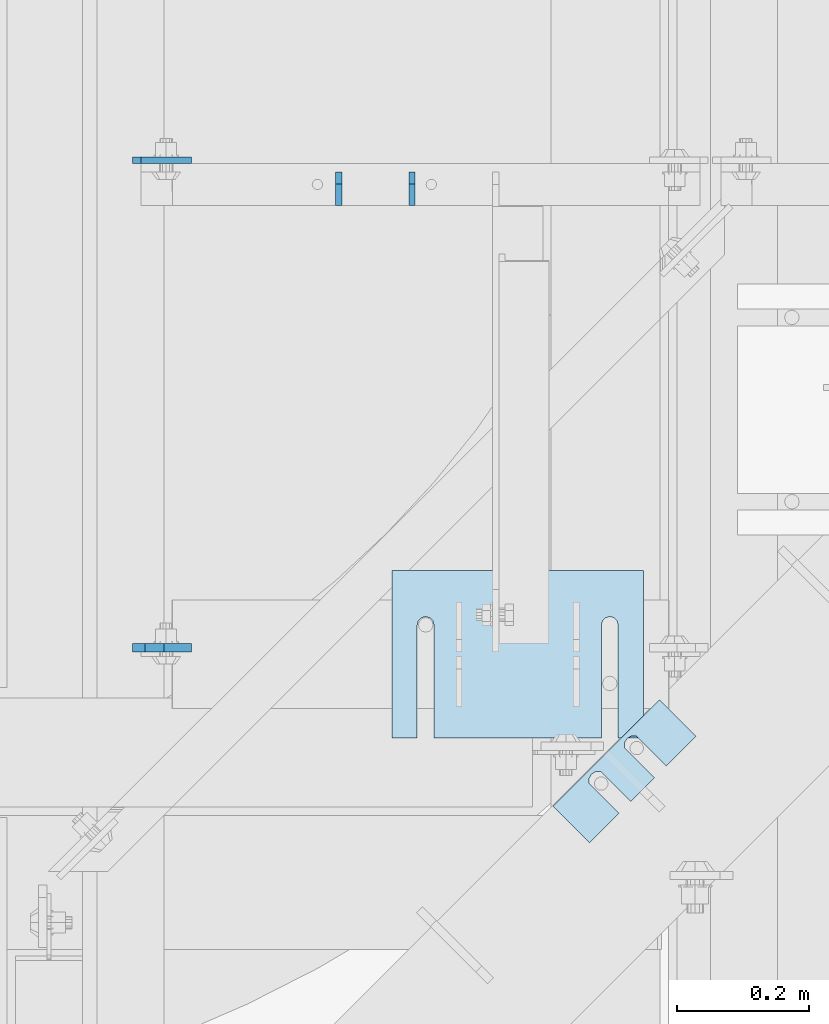
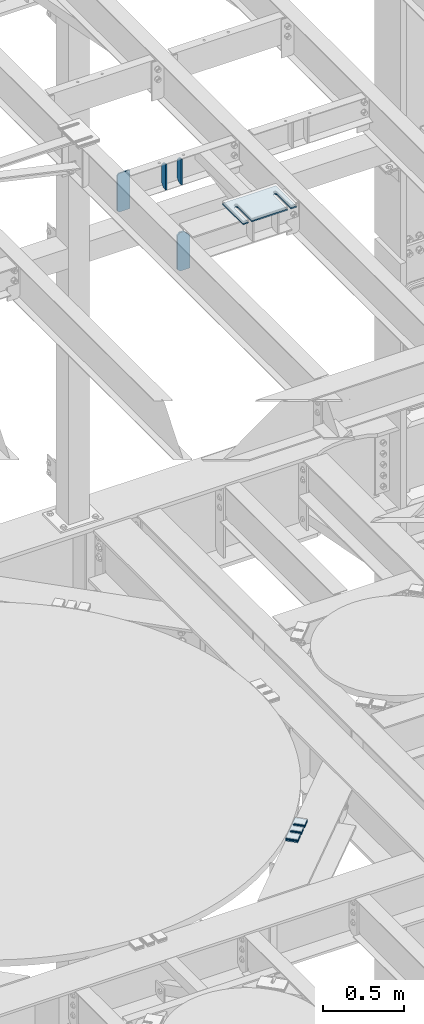
# One storey, part 1784 of 1876: 9 plates, 7 elements without a shape of their own.
"""IFC2X3 building model written with IfcOpenShell, lengths in millimetres."""

from ifc_helpers import new_model, si_unit, frame, origin_with_axes, place, context, subcontext, project, spatial, faceted_brep, material, type_object, element, aggregate, save


model = new_model("IFC2X3")

# Units and contexts
model_context = context("Model", 3, precision=1e-05, world=origin_with_axes())
body_context = subcontext(model_context, "Body", "Model", "MODEL_VIEW")
ifc_project = project(units=[si_unit("LENGTHUNIT", "METRE", prefix="MILLI"), si_unit("AREAUNIT", "SQUARE_METRE"), si_unit("VOLUMEUNIT", "CUBIC_METRE"), si_unit("MASSUNIT", "GRAM", prefix="KILO"), si_unit("TIMEUNIT", "SECOND"), si_unit("PLANEANGLEUNIT", "RADIAN"), si_unit("SOLIDANGLEUNIT", "STERADIAN"), si_unit("THERMODYNAMICTEMPERATUREUNIT", "DEGREE_CELSIUS"), si_unit("LUMINOUSINTENSITYUNIT", "LUMEN")], contexts=[model_context])

# Site, building, storey
site_placement = place(None, origin_with_axes())
site = spatial("IfcSite", under=ifc_project, at=site_placement, CompositionType="ELEMENT")
building_placement = place(site_placement, origin_with_axes())
building = spatial("IfcBuilding", under=site, at=building_placement, Name="Undefined", CompositionType="ELEMENT")
storey_placement = place(building_placement, origin_with_axes())
storey = spatial("IfcBuildingStorey", under=building, at=storey_placement, Name="Undefined", CompositionType="ELEMENT", Elevation=0.0)

# Assembly, plates
assembly_1_placement = place(storey_placement, origin_with_axes())
assembly_1 = element("IfcElementAssembly", 1, at=assembly_1_placement, inside=storey, Name="BEAM", AssemblyPlace="NOTDEFINED", PredefinedType="RIGID_FRAME")
ifc_material = material(Name="STEEL/A36")
plate_type_1 = type_object("IfcPlateType", PredefinedType="NOTDEFINED")
plate_1_placement = place(assembly_1_placement, frame((3835.4, 11014.0754999161, 17684.75), z_axis=(0.0, 0.0, 1.0), x_axis=(1.0, 0.0, 0.0)))
plate_1 = element("IfcPlate", 2, at=plate_1_placement, type_object=plate_type_1, material=ifc_material, Name="PLATE", context=body_context, shape_type="Brep", body=[
    faceted_brep([(3.7040990719106e-08, -4.76249999999982, 12.6999998092651), (0.0, -4.76249999999982, 279.40000629425), (0.0, 4.76249999999982, 279.40000629425), (3.70396264770534e-08, 4.76249999999982, 12.6999998092651), (12.6999998092651, -4.76249999999982, 292.100006103516), (12.6999998092651, 4.76249999999982, 292.100006103516), (88.9000015258789, -4.76249999999982, 292.100006103516), (88.9000015258789, 4.76249999999982, 292.100006103516), (88.9000015258789, -4.76249999999982, 0.0), (88.9000015258789, 4.76249999999982, 0.0), (12.699999809267, -4.76249999999754, 1.09139364212751e-11), (12.6999998092651, 4.76250000000255, 1.09139364212751e-11)], [[[0, 1, 2, 3]], [[1, 4, 5, 2]], [[4, 6, 7, 5]], [[6, 8, 9, 7]], [[8, 10, 11, 9]], [[10, 0, 3, 11]], [[5, 7, 9, 11, 3, 2]], [[10, 8, 6, 4, 1, 0]]]),
])
plate_type_2 = type_object("IfcPlateType", PredefinedType="NOTDEFINED")
plate_2_placement = place(assembly_1_placement, frame((3835.4, 10274.3012879372, 17686.3375), z_axis=(0.0, 0.0, 1.0), x_axis=(1.0, 0.0, 0.0)))
plate_2 = element("IfcPlate", 3, at=plate_2_placement, type_object=plate_type_2, material=ifc_material, Name="PLATE", context=body_context, shape_type="Brep", body=[
    faceted_brep([(0.0, -6.35000000000036, 271.462512969971), (19.0499992370605, -6.35000000000036, 290.512512207031), (19.0499992370605, 6.35000000000036, 290.512512207031), (0.0, 6.35000000000036, 271.462512969971), (0.0, -6.35000000000196, 19.0499992370605), (0.0, 6.35000000000105, 19.0499992370605), (19.0499992370642, -6.35000000000105, 0.0), (19.0499992370633, 6.35000000000105, 0.0), (88.9000015258789, -6.34999999999991, 0.0), (88.9000015258789, 6.34999999999991, 0.0), (88.9000015258789, -6.35000000000036, 249.237510681152), (47.625, -6.35000000000036, 290.512512207031), (47.625, 6.35000000000036, 290.512512207031), (88.9000015258789, 6.35000000000036, 249.237510681152)], [[[0, 1, 2, 3]], [[4, 0, 3, 5]], [[6, 4, 5, 7]], [[8, 6, 7, 9]], [[6, 8, 10, 11, 1, 0, 4]], [[1, 11, 12, 2]], [[2, 12, 13, 9, 7, 5, 3]], [[10, 8, 9, 13]], [[11, 10, 13, 12]]]),
])
aggregate(assembly_1, [plate_2, plate_1])

# Assembly, plate
assembly_2_placement = place(storey_placement, origin_with_axes())
assembly_2 = element("IfcElementAssembly", 4, at=assembly_2_placement, inside=storey, Name="SHIM PLATE", AssemblyPlace="NOTDEFINED", PredefinedType="RIGID_FRAME")
plate_type_3 = type_object("IfcPlateType", PredefinedType="NOTDEFINED")
plate_3_placement = place(assembly_2_placement, frame((4689.90078812532, 10140.2424941069, 13330.2365), z_axis=(-0.707124703959397, -0.707088857959405, 0.0), x_axis=(-0.707088857959406, 0.707124703959396, 0.0)))
plate_3 = element("IfcPlate", 5, at=plate_3_placement, type_object=plate_type_3, material=ifc_material, Name="SHIM PLATE", context=body_context, shape_type="Brep", body=[
    faceted_brep([(-2.69435986410826e-07, -1.58749999999964, 88.9036802523951), (-2.69435986410826e-07, 1.58749999999964, 88.9036802523951), (64.2890073715644, 1.58749999999964, 88.9052190745733), (64.2890073715644, -1.58749999999964, 88.9052190745733), (69.5243873298787, 1.58749999999964, 83.491558410592), (69.5243873298787, -1.58749999999964, 83.491558410592), (64.2896161919234, -1.58749999999964, 63.5071916498646), (64.2896161919234, 1.58749999999964, 63.5071916498646), (-1.92456354852766e-07, 1.58749999999964, 63.5036806291737), (-1.92456354852766e-07, -1.58749999999964, 63.5036806291737), (69.5247366006934, -1.58749999999964, 68.9211033039355), (69.5247366006934, 1.58749999999964, 68.9211033039355), (71.4330651893342, -1.58749999999964, 76.2063766063084), (71.4330651893342, 1.58749999999964, 76.2063766063084), (64.2877911166179, -1.58749999999964, 139.707191628079), (64.2877911166179, 1.58749999999964, 139.707191628079), (-4.23391611548141e-07, 1.58749999999964, 139.703680607395), (-4.23391611548141e-07, -1.58749999999964, 139.703680607395), (69.522911525386, -1.58749999999964, 145.121103282152), (69.522911525386, 1.58749999999964, 145.121103282152), (71.4312401140269, -1.58749999999964, 152.406376584525), (71.4312401140269, 1.58749999999964, 152.406376584525), (69.5225622545713, -1.58749999999964, 159.691558388808), (69.5225622545713, 1.58749999999964, 159.691558388808), (64.2871822962588, -1.58749999999964, 165.105219052789), (64.2871822962588, 1.58749999999964, 165.105219052789), (-5.00371243106201e-07, -1.58749999999964, 165.103680230615), (-5.00371243106201e-07, 1.58749999999964, 165.103680230615), (-6.92813046043739e-07, -1.58749999999964, 228.601303100699), (-6.92813046043739e-07, 1.58749999999964, 228.601303100699), (78.1460113524699, -1.58749999999964, 228.601303100651), (78.1460113524699, 1.58749999999964, 228.601303100651), (78.1460113525918, -1.58749999999964, -4.72937244921923e-11), (78.1460113525918, 1.58749999999964, -4.72937244921923e-11), (9.09494701772928e-13, -1.58750000000146, 4.54747350886464e-13), (9.09494701772928e-13, 1.58750000000146, 4.54747350886464e-13)], [[[0, 1, 2, 3]], [[3, 2, 4, 5]], [[6, 7, 8, 9]], [[10, 11, 7, 6]], [[12, 13, 11, 10]], [[5, 4, 13, 12]], [[14, 15, 16, 17]], [[18, 19, 15, 14]], [[20, 21, 19, 18]], [[22, 23, 21, 20]], [[24, 25, 23, 22]], [[26, 27, 25, 24]], [[28, 29, 27, 26]], [[28, 30, 31, 29]], [[30, 32, 33, 31]], [[32, 34, 35, 33]], [[35, 34, 9, 8]], [[2, 1, 16, 15, 19, 21, 23, 25, 27, 29, 31, 33, 35, 8, 7, 11, 13, 4]], [[17, 16, 1, 0]], [[6, 9, 34, 32, 30, 28, 26, 24, 22, 20, 18, 14, 17, 0, 3, 5, 12, 10]]]),
])
aggregate(assembly_2, [plate_3])

assembly_3_placement = place(storey_placement, origin_with_axes())
assembly_3 = element("IfcElementAssembly", 6, at=assembly_3_placement, inside=storey, Name="SHIM PLATE", AssemblyPlace="NOTDEFINED", PredefinedType="RIGID_FRAME")
plate_type_4 = type_object("IfcPlateType", PredefinedType="NOTDEFINED")
plate_4_placement = place(assembly_3_placement, frame((4689.90078812532, 10140.2424941069, 13326.268), z_axis=(-0.707124703959397, -0.707088857959405, 0.0), x_axis=(-0.707088857959406, 0.707124703959396, 0.0)))
plate_4 = element("IfcPlate", 7, at=plate_4_placement, type_object=plate_type_4, material=ifc_material, Name="SHIM PLATE", context=body_context, shape_type="Brep", body=[
    faceted_brep([(-2.69435986410826e-07, -2.3809999999994, 88.9036802523951), (-2.69435986410826e-07, 2.3809999999994, 88.9036802523951), (64.2890073715644, 2.3809999999994, 88.9052190745733), (64.2890073715644, -2.3809999999994, 88.9052190745733), (69.5243873298787, 2.3809999999994, 83.491558410592), (69.5243873298787, -2.3809999999994, 83.491558410592), (64.2896161919234, -2.3809999999994, 63.5071916498646), (64.2896161919234, 2.3809999999994, 63.5071916498646), (-1.92456354852766e-07, 2.3809999999994, 63.5036806291737), (-1.92456354852766e-07, -2.3809999999994, 63.5036806291737), (69.5247366006934, -2.3809999999994, 68.9211033039355), (69.5247366006934, 2.3809999999994, 68.9211033039355), (71.4330651893342, -2.3809999999994, 76.2063766063084), (71.4330651893342, 2.3809999999994, 76.2063766063084), (64.2877911166179, -2.3809999999994, 139.707191628079), (64.2877911166179, 2.3809999999994, 139.707191628079), (-4.23391611548141e-07, 2.3809999999994, 139.703680607395), (-4.23391611548141e-07, -2.3809999999994, 139.703680607395), (69.522911525386, -2.3809999999994, 145.121103282152), (69.522911525386, 2.3809999999994, 145.121103282152), (71.4312401140269, -2.3809999999994, 152.406376584525), (71.4312401140269, 2.3809999999994, 152.406376584525), (69.5225622545713, -2.3809999999994, 159.691558388808), (69.5225622545713, 2.3809999999994, 159.691558388808), (64.2871822962588, -2.3809999999994, 165.105219052789), (64.2871822962588, 2.3809999999994, 165.105219052789), (-5.00371243106201e-07, -2.3809999999994, 165.103680230615), (-5.00371243106201e-07, 2.3809999999994, 165.103680230615), (-6.92813046043739e-07, -2.3809999999994, 228.601303100699), (-6.92813046043739e-07, 2.3809999999994, 228.601303100699), (78.1460113524699, -2.3809999999994, 228.601303100651), (78.1460113524699, 2.3809999999994, 228.601303100651), (78.1460113525918, -2.3809999999994, -4.72937244921923e-11), (78.1460113525918, 2.3809999999994, -4.72937244921923e-11), (0.0, -2.38100000000122, 4.54747350886464e-13), (0.0, 2.38100000000122, 4.54747350886464e-13)], [[[0, 1, 2, 3]], [[3, 2, 4, 5]], [[6, 7, 8, 9]], [[10, 11, 7, 6]], [[12, 13, 11, 10]], [[5, 4, 13, 12]], [[14, 15, 16, 17]], [[18, 19, 15, 14]], [[20, 21, 19, 18]], [[22, 23, 21, 20]], [[24, 25, 23, 22]], [[26, 27, 25, 24]], [[28, 29, 27, 26]], [[28, 30, 31, 29]], [[30, 32, 33, 31]], [[32, 34, 35, 33]], [[35, 34, 9, 8]], [[2, 1, 16, 15, 19, 21, 23, 25, 27, 29, 31, 33, 35, 8, 7, 11, 13, 4]], [[17, 16, 1, 0]], [[6, 9, 34, 32, 30, 28, 26, 24, 22, 20, 18, 14, 17, 0, 3, 5, 12, 10]]]),
])
aggregate(assembly_3, [plate_4])

assembly_4_placement = place(storey_placement, origin_with_axes())
assembly_4 = element("IfcElementAssembly", 8, at=assembly_4_placement, inside=storey, Name="SHIM PLATE", AssemblyPlace="NOTDEFINED", PredefinedType="RIGID_FRAME")
plate_5_placement = place(assembly_4_placement, frame((4689.90078812532, 10140.2424941069, 13321.506), z_axis=(-0.707124703959397, -0.707088857959405, 0.0), x_axis=(-0.707088857959406, 0.707124703959396, 0.0)))
plate_5 = element("IfcPlate", 9, at=plate_5_placement, type_object=plate_type_4, material=ifc_material, Name="SHIM PLATE", context=body_context, shape_type="Brep", body=[
    faceted_brep([(-2.69435986410826e-07, -2.3809999999994, 88.9036802523951), (-2.69435986410826e-07, 2.3809999999994, 88.9036802523951), (64.2890073715644, 2.3809999999994, 88.9052190745733), (64.2890073715644, -2.3809999999994, 88.9052190745733), (69.5243873298787, 2.3809999999994, 83.491558410592), (69.5243873298787, -2.3809999999994, 83.491558410592), (64.2896161919234, -2.3809999999994, 63.5071916498646), (64.2896161919234, 2.3809999999994, 63.5071916498646), (-1.92456354852766e-07, 2.3809999999994, 63.5036806291737), (-1.92456354852766e-07, -2.3809999999994, 63.5036806291737), (69.5247366006934, -2.3809999999994, 68.9211033039355), (69.5247366006934, 2.3809999999994, 68.9211033039355), (71.4330651893342, -2.3809999999994, 76.2063766063084), (71.4330651893342, 2.3809999999994, 76.2063766063084), (64.2877911166179, -2.3809999999994, 139.707191628079), (64.2877911166179, 2.3809999999994, 139.707191628079), (-4.23391611548141e-07, 2.3809999999994, 139.703680607395), (-4.23391611548141e-07, -2.3809999999994, 139.703680607395), (69.522911525386, -2.3809999999994, 145.121103282152), (69.522911525386, 2.3809999999994, 145.121103282152), (71.4312401140269, -2.3809999999994, 152.406376584525), (71.4312401140269, 2.3809999999994, 152.406376584525), (69.5225622545713, -2.3809999999994, 159.691558388808), (69.5225622545713, 2.3809999999994, 159.691558388808), (64.2871822962588, -2.3809999999994, 165.105219052789), (64.2871822962588, 2.3809999999994, 165.105219052789), (-5.00371243106201e-07, -2.3809999999994, 165.103680230615), (-5.00371243106201e-07, 2.3809999999994, 165.103680230615), (-6.92813046043739e-07, -2.3809999999994, 228.601303100699), (-6.92813046043739e-07, 2.3809999999994, 228.601303100699), (78.1460113524699, -2.3809999999994, 228.601303100651), (78.1460113524699, 2.3809999999994, 228.601303100651), (78.1460113525918, -2.3809999999994, -4.72937244921923e-11), (78.1460113525918, 2.3809999999994, -4.72937244921923e-11), (0.0, -2.38100000000122, 4.54747350886464e-13), (0.0, 2.38100000000122, 4.54747350886464e-13)], [[[0, 1, 2, 3]], [[3, 2, 4, 5]], [[6, 7, 8, 9]], [[10, 11, 7, 6]], [[12, 13, 11, 10]], [[5, 4, 13, 12]], [[14, 15, 16, 17]], [[18, 19, 15, 14]], [[20, 21, 19, 18]], [[22, 23, 21, 20]], [[24, 25, 23, 22]], [[26, 27, 25, 24]], [[28, 29, 27, 26]], [[28, 30, 31, 29]], [[30, 32, 33, 31]], [[32, 34, 35, 33]], [[35, 34, 9, 8]], [[2, 1, 16, 15, 19, 21, 23, 25, 27, 29, 31, 33, 35, 8, 7, 11, 13, 4]], [[17, 16, 1, 0]], [[6, 9, 34, 32, 30, 28, 26, 24, 22, 20, 18, 14, 17, 0, 3, 5, 12, 10]]]),
])
aggregate(assembly_4, [plate_5])

assembly_5_placement = place(storey_placement, origin_with_axes())
assembly_5 = element("IfcElementAssembly", 10, at=assembly_5_placement, inside=storey, Name="SHIM PLATE", AssemblyPlace="NOTDEFINED", PredefinedType="RIGID_FRAME")
plate_type_5 = type_object("IfcPlateType", PredefinedType="NOTDEFINED")
plate_6_placement = place(assembly_5_placement, frame((4689.90078812532, 10140.2424941069, 13314.3625), z_axis=(-0.707124703959397, -0.707088857959405, 0.0), x_axis=(-0.707088857959406, 0.707124703959396, 0.0)))
plate_6 = element("IfcPlate", 11, at=plate_6_placement, type_object=plate_type_5, material=ifc_material, Name="SHIM PLATE", context=body_context, shape_type="Brep", body=[
    faceted_brep([(-2.69435986410826e-07, -4.76250000000073, 88.9036802523951), (-2.69435986410826e-07, 4.76250000000073, 88.9036802523951), (64.2890073715644, 4.76250000000073, 88.9052190745733), (64.2890073715644, -4.76250000000073, 88.9052190745733), (69.5243873298787, 4.76250000000073, 83.491558410592), (69.5243873298787, -4.76250000000073, 83.491558410592), (64.2896161919234, -4.76250000000073, 63.5071916498646), (64.2896161919234, 4.76250000000073, 63.5071916498646), (-1.92456354852766e-07, 4.76250000000073, 63.5036806291737), (-1.92456354852766e-07, -4.76250000000073, 63.5036806291737), (69.5247366006934, -4.76250000000073, 68.9211033039355), (69.5247366006934, 4.76250000000073, 68.9211033039355), (71.4330651893342, -4.76250000000073, 76.2063766063084), (71.4330651893342, 4.76250000000073, 76.2063766063084), (64.2877911166179, -4.76250000000073, 139.707191628079), (64.2877911166179, 4.76250000000073, 139.707191628079), (-4.23391611548141e-07, 4.76250000000073, 139.703680607395), (-4.23391611548141e-07, -4.76250000000073, 139.703680607395), (69.522911525386, -4.76250000000073, 145.121103282152), (69.522911525386, 4.76250000000073, 145.121103282152), (71.4312401140269, -4.76250000000073, 152.406376584525), (71.4312401140269, 4.76250000000073, 152.406376584525), (69.5225622545713, -4.76250000000073, 159.691558388808), (69.5225622545713, 4.76250000000073, 159.691558388808), (64.2871822962588, -4.76250000000073, 165.105219052789), (64.2871822962588, 4.76250000000073, 165.105219052789), (-5.00371243106201e-07, -4.76250000000073, 165.103680230615), (-5.00371243106201e-07, 4.76250000000073, 165.103680230615), (-6.92813046043739e-07, -4.76250000000073, 228.601303100699), (-6.92813046043739e-07, 4.76250000000073, 228.601303100699), (78.1460113524699, -4.76250000000073, 228.601303100651), (78.1460113524699, 4.76250000000073, 228.601303100651), (78.1460113525918, -4.76250000000073, -4.72937244921923e-11), (78.1460113525918, 4.76250000000073, -4.72937244921923e-11), (0.0, -4.76249999999982, 0.0), (0.0, 4.76249999999982, 0.0)], [[[0, 1, 2, 3]], [[3, 2, 4, 5]], [[6, 7, 8, 9]], [[10, 11, 7, 6]], [[12, 13, 11, 10]], [[5, 4, 13, 12]], [[14, 15, 16, 17]], [[18, 19, 15, 14]], [[20, 21, 19, 18]], [[22, 23, 21, 20]], [[24, 25, 23, 22]], [[26, 27, 25, 24]], [[28, 29, 27, 26]], [[28, 30, 31, 29]], [[30, 32, 33, 31]], [[32, 34, 35, 33]], [[35, 34, 9, 8]], [[2, 1, 16, 15, 19, 21, 23, 25, 27, 29, 31, 33, 35, 8, 7, 11, 13, 4]], [[17, 16, 1, 0]], [[6, 9, 34, 32, 30, 28, 26, 24, 22, 20, 18, 14, 17, 0, 3, 5, 12, 10]]]),
])
aggregate(assembly_5, [plate_6])

assembly_6_placement = place(storey_placement, origin_with_axes())
assembly_6 = element("IfcElementAssembly", 12, at=assembly_6_placement, inside=storey, Name="SHIM PLATE", AssemblyPlace="NOTDEFINED", PredefinedType="RIGID_FRAME")
plate_type_6 = type_object("IfcPlateType", PredefinedType="NOTDEFINED")
plate_7_placement = place(assembly_6_placement, frame((4610.09773210635, 10391.7760609403, 17987.9625), z_axis=(0.0, -1.0, 0.0), x_axis=(-1.0, 0.0, 0.0)))
plate_7 = element("IfcPlate", 13, at=plate_7_placement, type_object=plate_type_6, material=ifc_material, Name="SHIM PLATE", context=body_context, shape_type="Brep", body=[
    faceted_brep([(38.1710562683074, -4.76250000000073, 253.999557495119), (38.1732778844053, -4.76250000000073, 82.6182316462764), (38.1732778844053, 4.76250000000073, 82.6182316462764), (38.1710562683074, 4.76250000000073, 253.999557495119), (39.8747477728821, -4.76250000000073, 76.2682283464169), (39.8747477728821, 4.76250000000073, 76.2682283464169), (44.523266268131, -4.76250000000073, 71.6196998169826), (44.523266268131, 4.76250000000073, 71.6196998169826), (50.8732658952267, -4.76250000000073, 69.9182162215529), (50.8732658952267, 4.76250000000073, 69.9182162215529), (57.2232684284982, -4.76250000000073, 71.6196889709886), (57.2232684284982, 4.76250000000073, 71.6196889709886), (61.8717948635667, -4.76250000000073, 76.2682095606051), (61.8717948635667, 4.76250000000073, 76.2682095606051), (63.5732755980398, -4.76250000000073, 82.6182099542939), (63.5732755980398, 4.76250000000073, 82.6182099542939), (63.5710539816291, -4.76250000000073, 253.999557596195), (63.5710539816291, 4.76250000000073, 253.99955749512), (0.0, -4.76249999999982, 0.0), (1.89073648471094e-05, -4.76250000000073, 253.999557495117), (1.89073648471094e-05, 4.76250000000073, 253.999557495117), (0.0, 4.76249999999982, 0.0), (380.998474121094, -4.76250000000073, -2.41016095969826e-11), (380.998474121094, 4.76250000000073, -2.41016095969826e-11), (380.998504638661, -4.76250000000073, 253.999557495133), (380.998504638661, 4.76250000000073, 253.999557495133), (342.971054337228, 4.76250000000073, 253.999557495132), (342.971054337228, -4.76250000000073, 253.999557596208), (342.973275782132, 4.76250000000073, 82.6182252130961), (342.973275782132, -4.76250000000073, 82.6182252130961), (341.271801399192, 4.76250000000073, 76.2682205744086), (341.271801399192, -4.76250000000073, 76.2682205744086), (336.623277411347, 4.76250000000073, 71.6196940636119), (336.623277411347, -4.76250000000073, 71.6196940636119), (330.273273696123, 4.76250000000073, 69.9182162342554), (330.273273696123, -4.76250000000073, 69.9182162342554), (323.923270846187, 4.76250000000073, 71.6196972929051), (323.923270846187, -4.76250000000073, 71.6196972929051), (319.274749222349, 4.76250000000073, 76.2682261677069), (319.274749222349, -4.76250000000073, 76.2682261677069), (317.573278068704, 4.76250000000073, 82.6182316716777), (317.573278068704, -4.76250000000073, 82.6182316716777), (317.571056623908, -4.76250000000073, 253.99955749513), (317.571056623908, 4.76250000000073, 253.99955749513)], [[[0, 1, 2, 3]], [[4, 5, 2, 1]], [[6, 7, 5, 4]], [[8, 9, 7, 6]], [[10, 11, 9, 8]], [[12, 13, 11, 10]], [[14, 15, 13, 12]], [[16, 17, 15, 14]], [[18, 19, 20, 21]], [[22, 18, 21, 23]], [[24, 22, 23, 25]], [[24, 25, 26, 27]], [[27, 26, 28, 29]], [[29, 28, 30, 31]], [[31, 30, 32, 33]], [[33, 32, 34, 35]], [[35, 34, 36, 37]], [[37, 36, 38, 39]], [[39, 38, 40, 41]], [[42, 41, 40, 43]], [[12, 10, 8, 6, 4, 1, 0, 19, 18, 22, 24, 27, 29, 31, 33, 35, 37, 39, 41, 42, 16, 14]], [[20, 19, 0, 3]], [[43, 40, 38, 36, 34, 32, 30, 28, 26, 25, 23, 21, 20, 3, 2, 5, 7, 9, 11, 13, 15, 17]], [[42, 43, 17, 16]]]),
])
aggregate(assembly_6, [plate_7])

# Assembly, plates
assembly_7_placement = place(storey_placement, origin_with_axes())
assembly_7 = element("IfcElementAssembly", 14, at=assembly_7_placement, inside=storey, Name="BEAM", AssemblyPlace="NOTDEFINED", PredefinedType="RIGID_FRAME")
plate_type_7 = type_object("IfcPlateType", PredefinedType="NOTDEFINED")
plate_8_placement = place(assembly_7_placement, frame((4148.13743973152, 10945.8125, 17784.2358113043), z_axis=(0.0, -0.164348325034458, 0.986402366206797), x_axis=(0.0, 0.986402366206797, 0.164348325034458)))
plate_8 = element("IfcPlate", 15, at=plate_8_placement, type_object=plate_type_7, material=ifc_material, Name="PLATE", context=body_context, shape_type="Brep", body=[
    faceted_brep([(0.0, -4.76249999999982, 0.0), (32.0008087158794, -4.76249999999982, 192.081680297815), (32.0008087158794, 4.76249999999982, 192.081680297815), (0.0, 4.76249999999982, 0.0), (62.6982748962027, -4.76249999999982, 181.561281061485), (62.6982748962027, 4.76249999999982, 181.561281061485), (77.5887637589458, -4.76249999999982, 156.594231983478), (77.5887637589458, 4.76249999999982, 156.594231983478), (54.6307491805464, -4.76249999999982, 18.791006663906), (54.6307491805464, 4.76249999999982, 18.791006663906), (32.4501686096137, -4.76249999999982, -1.63709046319127e-11), (32.4501686096137, 4.76249999999982, -1.63709046319127e-11)], [[[0, 1, 2, 3]], [[1, 4, 5, 2]], [[4, 6, 7, 5]], [[6, 8, 9, 7]], [[8, 10, 11, 9]], [[10, 0, 3, 11]], [[5, 7, 9, 11, 3, 2]], [[10, 8, 6, 4, 1, 0]]]),
])
plate_9_placement = place(assembly_7_placement, frame((4259.26243973152, 10945.8125, 17784.2357237912), z_axis=(0.0, -0.164348325034458, 0.986402366206797), x_axis=(0.0, 0.986402366206797, 0.164348325034458)))
plate_9 = element("IfcPlate", 16, at=plate_9_placement, type_object=plate_type_7, material=ifc_material, Name="PLATE", context=body_context, shape_type="Brep", body=[
    faceted_brep([(0.0, -4.76249999999982, 0.0), (32.0008087158794, -4.76249999999982, 192.081680297815), (32.0008087158794, 4.76249999999982, 192.081680297815), (0.0, 4.76249999999982, 0.0), (62.6982748962027, -4.76249999999982, 181.561281061485), (62.6982748962027, 4.76249999999982, 181.561281061485), (77.5887637589458, -4.76249999999982, 156.594231983478), (77.5887637589458, 4.76249999999982, 156.594231983478), (54.6307491805464, -4.76249999999982, 18.791006663906), (54.6307491805464, 4.76249999999982, 18.791006663906), (32.4501686096137, -4.76249999999982, -1.63709046319127e-11), (32.4501686096137, 4.76249999999982, -1.63709046319127e-11)], [[[0, 1, 2, 3]], [[1, 4, 5, 2]], [[4, 6, 7, 5]], [[6, 8, 9, 7]], [[8, 10, 11, 9]], [[10, 0, 3, 11]], [[5, 7, 9, 11, 3, 2]], [[10, 8, 6, 4, 1, 0]]]),
])
aggregate(assembly_7, [plate_8, plate_9])

save(model, "model.ifc")
